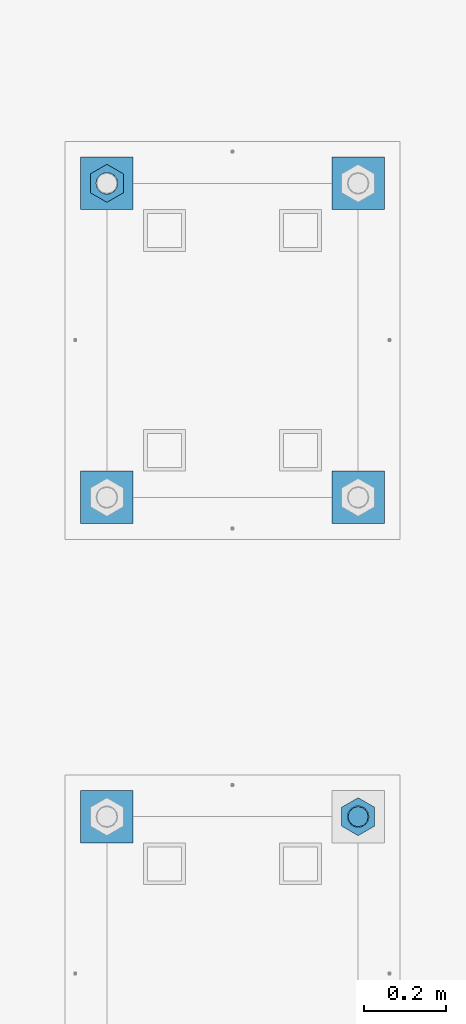
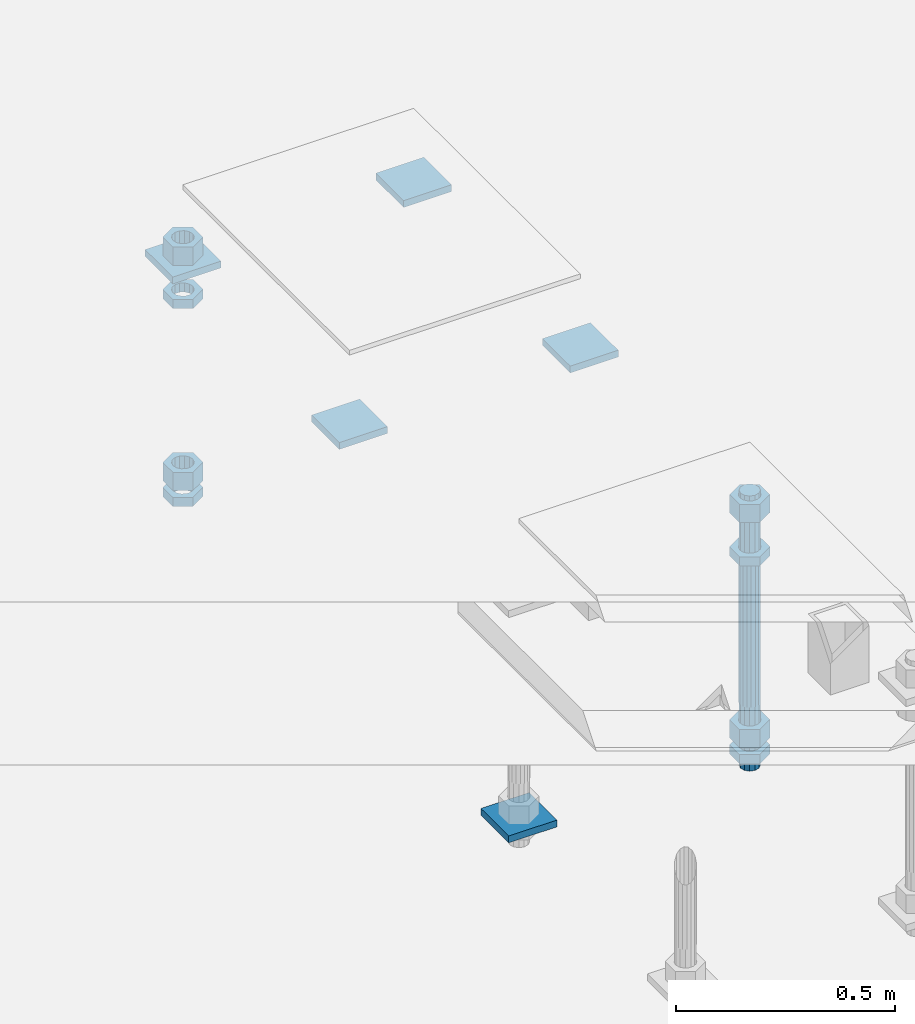
# One storey, part 2617 of 3843: 14 beams, 2 elements without a shape of their own.
"""IFC2X3 building model written with IfcOpenShell, lengths in millimetres."""

from ifc_helpers import new_model, si_unit, frame, origin_with_axes, place, context, subcontext, project, spatial, faceted_brep, material, type_object, element, aggregate, save


model = new_model("IFC2X3")

# Units and contexts
model_context = context("Model", 3, precision=1e-05, world=origin_with_axes())
body_context = subcontext(model_context, "Body", "Model", "MODEL_VIEW")
ifc_project = project(units=[si_unit("LENGTHUNIT", "METRE", prefix="MILLI"), si_unit("AREAUNIT", "SQUARE_METRE"), si_unit("VOLUMEUNIT", "CUBIC_METRE"), si_unit("MASSUNIT", "GRAM", prefix="KILO"), si_unit("TIMEUNIT", "SECOND"), si_unit("PLANEANGLEUNIT", "RADIAN"), si_unit("SOLIDANGLEUNIT", "STERADIAN"), si_unit("THERMODYNAMICTEMPERATUREUNIT", "DEGREE_CELSIUS"), si_unit("LUMINOUSINTENSITYUNIT", "LUMEN")], contexts=[model_context])

# Site, building, storey
site_placement = place(None, origin_with_axes())
site = spatial("IfcSite", under=ifc_project, at=site_placement, CompositionType="ELEMENT")
building_placement = place(site_placement, origin_with_axes())
building = spatial("IfcBuilding", under=site, at=building_placement, Name="Undefined", CompositionType="ELEMENT")
storey_placement = place(building_placement, origin_with_axes())
storey = spatial("IfcBuildingStorey", under=building, at=storey_placement, Name="Undefined", CompositionType="ELEMENT", Elevation=0.0)

# Assembly, beams
assembly_1_placement = place(storey_placement, origin_with_axes())
assembly_1 = element("IfcElementAssembly", 1, at=assembly_1_placement, inside=storey, Name="TEMPLATE", AssemblyPlace="NOTDEFINED", PredefinedType="RIGID_FRAME")
ifc_material_1 = material(Name="STEEL/A36")
beam_type_1 = type_object("IfcBeamType", PredefinedType="NOTDEFINED")
beam_1_placement = place(assembly_1_placement, frame((111798.099998474, 2806.7, 29873.575), z_axis=(0.0, 1.0, 0.0), x_axis=(-1.0, 0.0, 0.0)))
beam_1 = element("IfcBeam", 2, at=beam_1_placement, type_object=beam_type_1, material=ifc_material_1, Name="WASHER_PLATE", context=body_context, shape_type="Brep", body=[
    faceted_brep([(0.0, 9.52500000000146, -63.5), (0.0, 9.52500000000146, 63.5), (127.0, 9.52500000000146, 63.5), (127.0, 9.52500000000146, -63.5), (0.0, -9.52500000000146, 63.5), (127.0, -9.52500000000146, 63.5), (0.0, -9.52500000000146, -63.5), (127.0, -9.52500000000146, -63.5)], [[[0, 1, 2, 3]], [[1, 4, 5, 2]], [[4, 6, 7, 5]], [[6, 0, 3, 7]], [[5, 7, 3, 2]], [[6, 4, 1, 0]]]),
])
beam_2_placement = place(assembly_1_placement, frame((112407.7, 2806.7, 29873.575), z_axis=(0.0, 1.0, 0.0), x_axis=(-1.0, 0.0, 0.0)))
beam_2 = element("IfcBeam", 3, at=beam_2_placement, type_object=beam_type_1, material=ifc_material_1, Name="WASHER_PLATE", context=body_context, shape_type="Brep", body=[
    faceted_brep([(0.0, 9.52500000000146, -63.5), (0.0, 9.52500000000146, 63.5), (127.0, 9.52500000000146, 63.5), (127.0, 9.52500000000146, -63.5), (0.0, -9.52500000000146, 63.5), (127.0, -9.52500000000146, 63.5), (0.0, -9.52500000000146, -63.5), (127.0, -9.52500000000146, -63.5)], [[[0, 1, 2, 3]], [[1, 4, 5, 2]], [[4, 6, 7, 5]], [[6, 0, 3, 7]], [[5, 7, 3, 2]], [[6, 4, 1, 0]]]),
])
beam_3_placement = place(assembly_1_placement, frame((112407.7, 3568.7, 29873.575), z_axis=(0.0, 1.0, 0.0), x_axis=(-1.0, 0.0, 0.0)))
beam_3 = element("IfcBeam", 4, at=beam_3_placement, type_object=beam_type_1, material=ifc_material_1, Name="WASHER_PLATE", context=body_context, shape_type="Brep", body=[
    faceted_brep([(0.0, 9.52500000000146, -63.5), (0.0, 9.52500000000146, 63.5), (127.0, 9.52500000000146, 63.5), (127.0, 9.52500000000146, -63.5), (0.0, -9.52500000000146, 63.5), (127.0, -9.52500000000146, 63.5), (0.0, -9.52500000000146, -63.5), (127.0, -9.52500000000146, -63.5)], [[[0, 1, 2, 3]], [[1, 4, 5, 2]], [[4, 6, 7, 5]], [[6, 0, 3, 7]], [[5, 7, 3, 2]], [[6, 4, 1, 0]]]),
])
beam_4_placement = place(assembly_1_placement, frame((111798.099998474, 3568.7, 29873.575), z_axis=(0.0, 1.0, 0.0), x_axis=(-1.0, 0.0, 0.0)))
beam_4 = element("IfcBeam", 5, at=beam_4_placement, type_object=beam_type_1, material=ifc_material_1, Name="WASHER_PLATE", context=body_context, shape_type="Brep", body=[
    faceted_brep([(0.0, 9.52500000000146, -63.5), (0.0, 9.52500000000146, 63.5), (127.0, 9.52500000000146, 63.5), (127.0, 9.52500000000146, -63.5), (0.0, -9.52500000000146, 63.5), (127.0, -9.52500000000146, 63.5), (0.0, -9.52500000000146, -63.5), (127.0, -9.52500000000146, -63.5)], [[[0, 1, 2, 3]], [[1, 4, 5, 2]], [[4, 6, 7, 5]], [[6, 0, 3, 7]], [[5, 7, 3, 2]], [[6, 4, 1, 0]]]),
])

# Assembly, beam
assembly_2_placement = place(storey_placement, origin_with_axes())
assembly_2 = element("IfcElementAssembly", 6, at=assembly_2_placement, inside=storey, Name="TEMPLATE", AssemblyPlace="NOTDEFINED", PredefinedType="RIGID_FRAME")
beam_5_placement = place(assembly_2_placement, frame((111798.099998474, 2032.00000000001, 29244.925), z_axis=(0.0, 1.0, 0.0), x_axis=(-1.0, 0.0, 0.0)))
beam_5 = element("IfcBeam", 7, at=beam_5_placement, type_object=beam_type_1, material=ifc_material_1, Name="WASHER_PLATE", context=body_context, shape_type="Brep", body=[
    faceted_brep([(0.0, 9.52500000000146, -63.5), (0.0, 9.52500000000146, 63.5), (127.0, 9.52500000000146, 63.5), (127.0, 9.52500000000146, -63.5), (0.0, -9.52500000000146, 63.5), (127.0, -9.52500000000146, 63.5), (0.0, -9.52500000000146, -63.5), (127.0, -9.52500000000146, -63.5)], [[[0, 1, 2, 3]], [[1, 4, 5, 2]], [[4, 6, 7, 5]], [[6, 0, 3, 7]], [[5, 7, 3, 2]], [[6, 4, 1, 0]]]),
])

# Beam
beam_type_2 = type_object("IfcBeamType", Name="2_HALF_NUT", PredefinedType="NOTDEFINED")
beam_6_placement = place(assembly_1_placement, frame((111734.599998474, 3568.70000000001, 29787.85), z_axis=(-1.0, 0.0, 0.0), x_axis=(0.0, 0.0, -1.0)))
beam_6 = element("IfcBeam", 8, at=beam_6_placement, type_object=beam_type_2, material=ifc_material_1, Name="NUT", ObjectType="2_HALF_NUT", context=body_context, shape_type="Brep", body=[
    faceted_brep([(0.0, -46.0369987487793, 0.0), (0.0, -23.0184993743896, -39.869213104248), (25.4000000000015, -23.0184993743896, -39.869213104248), (25.4000000000015, -46.0369987487793, 0.0), (0.0, 23.0184993743896, -39.869213104248), (25.4000000000015, 23.0184993743896, -39.869213104248), (0.0, 46.0369987487793, 0.0), (25.4000000000015, 46.0369987487793, 0.0), (0.0, 23.0184993743896, 39.869213104248), (25.4000000000015, 23.0184993743896, 39.869213104248), (0.0, -23.0184993743896, 39.869213104248), (25.4000000000015, -23.0184993743896, 39.869213104248), (0.0, 0.0, 26.1940002441406), (0.0, 11.3650617044477, 23.5999013092805), (25.4000000000015, 11.3650617044477, 23.5999013092805), (25.4000000000015, 0.0, 26.1940002441406), (0.0, 20.4791109456419, 16.3316083006721), (25.4000000000015, 20.4791109456419, 16.3316083006721), (0.0, 25.5370200498292, 5.82867859874386), (25.4000000000015, 25.5370200498292, 5.82867859874386), (0.0, 25.5370200498292, -5.82867859874386), (25.4000000000015, 25.5370200498292, -5.82867859874386), (0.0, 20.4791109456419, -16.3316083006721), (25.4000000000015, 20.4791109456419, -16.3316083006721), (0.0, 11.3650617044477, -23.5999013092805), (25.4000000000015, 11.3650617044477, -23.5999013092805), (0.0, 0.0, -26.1940002441406), (25.4000000000015, 0.0, -26.1940002441406), (0.0, -11.3650617044477, -23.5999013092805), (25.4000000000015, -11.3650617044477, -23.5999013092805), (0.0, -20.4791109456419, -16.3316083006721), (25.4000000000015, -20.4791109456419, -16.3316083006721), (0.0, -25.5370200498292, -5.82867859874386), (25.4000000000015, -25.5370200498292, -5.82867859874386), (0.0, -25.5370200498292, 5.82867859874386), (25.4000000000015, -25.5370200498292, 5.82867859874386), (0.0, -20.4791109456419, 16.3316083006721), (25.4000000000015, -20.4791109456419, 16.3316083006721), (0.0, -11.3650617044477, 23.5999013092805), (25.4000000000015, -11.3650617044477, 23.5999013092805)], [[[0, 1, 2, 3]], [[1, 4, 5, 2]], [[4, 6, 7, 5]], [[6, 8, 9, 7]], [[8, 10, 11, 9]], [[10, 0, 3, 11]], [[12, 13, 14, 15]], [[13, 16, 17, 14]], [[16, 18, 19, 17]], [[18, 20, 21, 19]], [[20, 22, 23, 21]], [[22, 24, 25, 23]], [[24, 26, 27, 25]], [[26, 28, 29, 27]], [[28, 30, 31, 29]], [[30, 32, 33, 31]], [[32, 34, 35, 33]], [[34, 36, 37, 35]], [[36, 38, 39, 37]], [[38, 12, 15, 39]], [[5, 7, 9, 11, 3, 2], [17, 19, 21, 23, 25, 27, 29, 31, 33, 35, 37, 39, 15, 14]], [[10, 8, 6, 4, 1, 0], [38, 36, 34, 32, 30, 28, 26, 24, 22, 20, 18, 16, 13, 12]]]),
])

beam_7_placement = place(assembly_1_placement, frame((111734.599998474, 3568.7, 29235.4), z_axis=(-1.0, 0.0, 0.0), x_axis=(0.0, 0.0, -1.0)))
beam_7 = element("IfcBeam", 9, at=beam_7_placement, type_object=beam_type_2, material=ifc_material_1, Name="NUT", ObjectType="2_HALF_NUT", context=body_context, shape_type="Brep", body=[
    faceted_brep([(0.0, -46.0369987487793, 0.0), (0.0, -23.0184993743896, -39.869213104248), (25.4000000000015, -23.0184993743896, -39.869213104248), (25.4000000000015, -46.0369987487793, 0.0), (0.0, 23.0184993743896, -39.869213104248), (25.4000000000015, 23.0184993743896, -39.869213104248), (0.0, 46.0369987487793, 0.0), (25.4000000000015, 46.0369987487793, 0.0), (0.0, 23.0184993743896, 39.869213104248), (25.4000000000015, 23.0184993743896, 39.869213104248), (0.0, -23.0184993743896, 39.869213104248), (25.4000000000015, -23.0184993743896, 39.869213104248), (0.0, 0.0, 26.1940002441406), (0.0, 11.3650617044477, 23.5999013092805), (25.4000000000015, 11.3650617044477, 23.5999013092805), (25.4000000000015, 0.0, 26.1940002441406), (0.0, 20.4791109456419, 16.3316083006721), (25.4000000000015, 20.4791109456419, 16.3316083006721), (0.0, 25.5370200498292, 5.82867859874386), (25.4000000000015, 25.5370200498292, 5.82867859874386), (0.0, 25.5370200498292, -5.82867859874386), (25.4000000000015, 25.5370200498292, -5.82867859874386), (0.0, 20.4791109456419, -16.3316083006721), (25.4000000000015, 20.4791109456419, -16.3316083006721), (0.0, 11.3650617044477, -23.5999013092805), (25.4000000000015, 11.3650617044477, -23.5999013092805), (0.0, 0.0, -26.1940002441406), (25.4000000000015, 0.0, -26.1940002441406), (0.0, -11.3650617044477, -23.5999013092805), (25.4000000000015, -11.3650617044477, -23.5999013092805), (0.0, -20.4791109456419, -16.3316083006721), (25.4000000000015, -20.4791109456419, -16.3316083006721), (0.0, -25.5370200498292, -5.82867859874386), (25.4000000000015, -25.5370200498292, -5.82867859874386), (0.0, -25.5370200498292, 5.82867859874386), (25.4000000000015, -25.5370200498292, 5.82867859874386), (0.0, -20.4791109456419, 16.3316083006721), (25.4000000000015, -20.4791109456419, 16.3316083006721), (0.0, -11.3650617044477, 23.5999013092805), (25.4000000000015, -11.3650617044477, 23.5999013092805)], [[[0, 1, 2, 3]], [[1, 4, 5, 2]], [[4, 6, 7, 5]], [[6, 8, 9, 7]], [[8, 10, 11, 9]], [[10, 0, 3, 11]], [[12, 13, 14, 15]], [[13, 16, 17, 14]], [[16, 18, 19, 17]], [[18, 20, 21, 19]], [[20, 22, 23, 21]], [[22, 24, 25, 23]], [[24, 26, 27, 25]], [[26, 28, 29, 27]], [[28, 30, 31, 29]], [[30, 32, 33, 31]], [[32, 34, 35, 33]], [[34, 36, 37, 35]], [[36, 38, 39, 37]], [[38, 12, 15, 39]], [[5, 7, 9, 11, 3, 2], [17, 19, 21, 23, 25, 27, 29, 31, 33, 35, 37, 39, 15, 14]], [[10, 8, 6, 4, 1, 0], [38, 36, 34, 32, 30, 28, 26, 24, 22, 20, 18, 16, 13, 12]]]),
])

beam_8_placement = place(assembly_2_placement, frame((112344.2, 2032.00000000001, 29787.85), z_axis=(-1.0, 0.0, 0.0), x_axis=(0.0, 0.0, -1.0)))
beam_8 = element("IfcBeam", 10, at=beam_8_placement, type_object=beam_type_2, material=ifc_material_1, Name="NUT", ObjectType="2_HALF_NUT", context=body_context, shape_type="Brep", body=[
    faceted_brep([(0.0, -46.0369987487793, 0.0), (0.0, -23.0184993743896, -39.869213104248), (25.4000000000015, -23.0184993743896, -39.869213104248), (25.4000000000015, -46.0369987487793, 0.0), (0.0, 23.0184993743896, -39.869213104248), (25.4000000000015, 23.0184993743896, -39.869213104248), (0.0, 46.0369987487793, 0.0), (25.4000000000015, 46.0369987487793, 0.0), (0.0, 23.0184993743896, 39.869213104248), (25.4000000000015, 23.0184993743896, 39.869213104248), (0.0, -23.0184993743896, 39.869213104248), (25.4000000000015, -23.0184993743896, 39.869213104248), (0.0, 0.0, 26.1940002441406), (0.0, 11.3650617044477, 23.5999013092805), (25.4000000000015, 11.3650617044477, 23.5999013092805), (25.4000000000015, 0.0, 26.1940002441406), (0.0, 20.4791109456419, 16.3316083006721), (25.4000000000015, 20.4791109456419, 16.3316083006721), (0.0, 25.5370200498292, 5.82867859874386), (25.4000000000015, 25.5370200498292, 5.82867859874386), (0.0, 25.5370200498292, -5.82867859874386), (25.4000000000015, 25.5370200498292, -5.82867859874386), (0.0, 20.4791109456419, -16.3316083006721), (25.4000000000015, 20.4791109456419, -16.3316083006721), (0.0, 11.3650617044477, -23.5999013092805), (25.4000000000015, 11.3650617044477, -23.5999013092805), (0.0, 0.0, -26.1940002441406), (25.4000000000015, 0.0, -26.1940002441406), (0.0, -11.3650617044477, -23.5999013092805), (25.4000000000015, -11.3650617044477, -23.5999013092805), (0.0, -20.4791109456419, -16.3316083006721), (25.4000000000015, -20.4791109456419, -16.3316083006721), (0.0, -25.5370200498292, -5.82867859874386), (25.4000000000015, -25.5370200498292, -5.82867859874386), (0.0, -25.5370200498292, 5.82867859874386), (25.4000000000015, -25.5370200498292, 5.82867859874386), (0.0, -20.4791109456419, 16.3316083006721), (25.4000000000015, -20.4791109456419, 16.3316083006721), (0.0, -11.3650617044477, 23.5999013092805), (25.4000000000015, -11.3650617044477, 23.5999013092805)], [[[0, 1, 2, 3]], [[1, 4, 5, 2]], [[4, 6, 7, 5]], [[6, 8, 9, 7]], [[8, 10, 11, 9]], [[10, 0, 3, 11]], [[12, 13, 14, 15]], [[13, 16, 17, 14]], [[16, 18, 19, 17]], [[18, 20, 21, 19]], [[20, 22, 23, 21]], [[22, 24, 25, 23]], [[24, 26, 27, 25]], [[26, 28, 29, 27]], [[28, 30, 31, 29]], [[30, 32, 33, 31]], [[32, 34, 35, 33]], [[34, 36, 37, 35]], [[36, 38, 39, 37]], [[38, 12, 15, 39]], [[5, 7, 9, 11, 3, 2], [17, 19, 21, 23, 25, 27, 29, 31, 33, 35, 37, 39, 15, 14]], [[10, 8, 6, 4, 1, 0], [38, 36, 34, 32, 30, 28, 26, 24, 22, 20, 18, 16, 13, 12]]]),
])

beam_9_placement = place(assembly_2_placement, frame((112344.2, 2032.0, 29235.4), z_axis=(-1.0, 0.0, 0.0), x_axis=(0.0, 0.0, -1.0)))
beam_9 = element("IfcBeam", 11, at=beam_9_placement, type_object=beam_type_2, material=ifc_material_1, Name="NUT", ObjectType="2_HALF_NUT", context=body_context, shape_type="Brep", body=[
    faceted_brep([(0.0, -46.0369987487793, 0.0), (0.0, -23.0184993743896, -39.869213104248), (25.4000000000015, -23.0184993743896, -39.869213104248), (25.4000000000015, -46.0369987487793, 0.0), (0.0, 23.0184993743896, -39.869213104248), (25.4000000000015, 23.0184993743896, -39.869213104248), (0.0, 46.0369987487793, 0.0), (25.4000000000015, 46.0369987487793, 0.0), (0.0, 23.0184993743896, 39.869213104248), (25.4000000000015, 23.0184993743896, 39.869213104248), (0.0, -23.0184993743896, 39.869213104248), (25.4000000000015, -23.0184993743896, 39.869213104248), (0.0, 0.0, 26.1940002441406), (0.0, 11.3650617044477, 23.5999013092805), (25.4000000000015, 11.3650617044477, 23.5999013092805), (25.4000000000015, 0.0, 26.1940002441406), (0.0, 20.4791109456419, 16.3316083006721), (25.4000000000015, 20.4791109456419, 16.3316083006721), (0.0, 25.5370200498292, 5.82867859874386), (25.4000000000015, 25.5370200498292, 5.82867859874386), (0.0, 25.5370200498292, -5.82867859874386), (25.4000000000015, 25.5370200498292, -5.82867859874386), (0.0, 20.4791109456419, -16.3316083006721), (25.4000000000015, 20.4791109456419, -16.3316083006721), (0.0, 11.3650617044477, -23.5999013092805), (25.4000000000015, 11.3650617044477, -23.5999013092805), (0.0, 0.0, -26.1940002441406), (25.4000000000015, 0.0, -26.1940002441406), (0.0, -11.3650617044477, -23.5999013092805), (25.4000000000015, -11.3650617044477, -23.5999013092805), (0.0, -20.4791109456419, -16.3316083006721), (25.4000000000015, -20.4791109456419, -16.3316083006721), (0.0, -25.5370200498292, -5.82867859874386), (25.4000000000015, -25.5370200498292, -5.82867859874386), (0.0, -25.5370200498292, 5.82867859874386), (25.4000000000015, -25.5370200498292, 5.82867859874386), (0.0, -20.4791109456419, 16.3316083006721), (25.4000000000015, -20.4791109456419, 16.3316083006721), (0.0, -11.3650617044477, 23.5999013092805), (25.4000000000015, -11.3650617044477, 23.5999013092805)], [[[0, 1, 2, 3]], [[1, 4, 5, 2]], [[4, 6, 7, 5]], [[6, 8, 9, 7]], [[8, 10, 11, 9]], [[10, 0, 3, 11]], [[12, 13, 14, 15]], [[13, 16, 17, 14]], [[16, 18, 19, 17]], [[18, 20, 21, 19]], [[20, 22, 23, 21]], [[22, 24, 25, 23]], [[24, 26, 27, 25]], [[26, 28, 29, 27]], [[28, 30, 31, 29]], [[30, 32, 33, 31]], [[32, 34, 35, 33]], [[34, 36, 37, 35]], [[36, 38, 39, 37]], [[38, 12, 15, 39]], [[5, 7, 9, 11, 3, 2], [17, 19, 21, 23, 25, 27, 29, 31, 33, 35, 37, 39, 15, 14]], [[10, 8, 6, 4, 1, 0], [38, 36, 34, 32, 30, 28, 26, 24, 22, 20, 18, 16, 13, 12]]]),
])

beam_type_3 = type_object("IfcBeamType", Name="2_HEAVY_HEX_NUT", PredefinedType="NOTDEFINED")
beam_10_placement = place(assembly_1_placement, frame((111734.599998474, 3568.70000000001, 29933.9), z_axis=(-1.0, 0.0, 0.0), x_axis=(0.0, 0.0, -1.0)))
beam_10 = element("IfcBeam", 12, at=beam_10_placement, type_object=beam_type_3, material=ifc_material_1, Name="NUT", ObjectType="2_HEAVY_HEX_NUT", context=body_context, shape_type="Brep", body=[
    faceted_brep([(0.0, -46.0369987487793, 0.0), (0.0, -23.0184993743896, -39.869213104248), (50.7999999999993, -23.0184993743896, -39.869213104248), (50.7999999999993, -46.0369987487793, 0.0), (0.0, 23.0184993743896, -39.869213104248), (50.7999999999993, 23.0184993743896, -39.869213104248), (0.0, 46.0369987487793, 0.0), (50.7999999999993, 46.0369987487793, 0.0), (0.0, 23.0184993743896, 39.869213104248), (50.7999999999993, 23.0184993743896, 39.869213104248), (0.0, -23.0184993743896, 39.869213104248), (50.7999999999993, -23.0184993743896, 39.869213104248), (0.0, 0.0, 26.1940002441406), (0.0, 11.3650617044477, 23.5999013092805), (50.7999999999993, 11.3650617044477, 23.5999013092805), (50.7999999999993, 0.0, 26.1940002441406), (0.0, 20.4791109456419, 16.3316083006721), (50.7999999999993, 20.4791109456419, 16.3316083006721), (0.0, 25.5370200498292, 5.82867859874386), (50.7999999999993, 25.5370200498292, 5.82867859874386), (0.0, 25.5370200498292, -5.82867859874386), (50.7999999999993, 25.5370200498292, -5.82867859874386), (0.0, 20.4791109456419, -16.3316083006721), (50.7999999999993, 20.4791109456419, -16.3316083006721), (0.0, 11.3650617044477, -23.5999013092805), (50.7999999999993, 11.3650617044477, -23.5999013092805), (0.0, 0.0, -26.1940002441406), (50.7999999999993, 0.0, -26.1940002441406), (0.0, -11.3650617044477, -23.5999013092805), (50.7999999999993, -11.3650617044477, -23.5999013092805), (0.0, -20.4791109456419, -16.3316083006721), (50.7999999999993, -20.4791109456419, -16.3316083006721), (0.0, -25.5370200498292, -5.82867859874386), (50.7999999999993, -25.5370200498292, -5.82867859874386), (0.0, -25.5370200498292, 5.82867859874386), (50.7999999999993, -25.5370200498292, 5.82867859874386), (0.0, -20.4791109456419, 16.3316083006721), (50.7999999999993, -20.4791109456419, 16.3316083006721), (0.0, -11.3650617044477, 23.5999013092805), (50.7999999999993, -11.3650617044477, 23.5999013092805)], [[[0, 1, 2, 3]], [[1, 4, 5, 2]], [[4, 6, 7, 5]], [[6, 8, 9, 7]], [[8, 10, 11, 9]], [[10, 0, 3, 11]], [[12, 13, 14, 15]], [[13, 16, 17, 14]], [[16, 18, 19, 17]], [[18, 20, 21, 19]], [[20, 22, 23, 21]], [[22, 24, 25, 23]], [[24, 26, 27, 25]], [[26, 28, 29, 27]], [[28, 30, 31, 29]], [[30, 32, 33, 31]], [[32, 34, 35, 33]], [[34, 36, 37, 35]], [[36, 38, 39, 37]], [[38, 12, 15, 39]], [[5, 7, 9, 11, 3, 2], [17, 19, 21, 23, 25, 27, 29, 31, 33, 35, 37, 39, 15, 14]], [[10, 8, 6, 4, 1, 0], [38, 36, 34, 32, 30, 28, 26, 24, 22, 20, 18, 16, 13, 12]]]),
])

beam_11_placement = place(assembly_1_placement, frame((111734.599998474, 3568.70000000001, 29305.25), z_axis=(-1.0, 0.0, 0.0), x_axis=(0.0, 0.0, -1.0)))
beam_11 = element("IfcBeam", 13, at=beam_11_placement, type_object=beam_type_3, material=ifc_material_1, Name="NUT", ObjectType="2_HEAVY_HEX_NUT", context=body_context, shape_type="Brep", body=[
    faceted_brep([(0.0, -46.0369987487793, 0.0), (0.0, -23.0184993743896, -39.869213104248), (50.7999999999993, -23.0184993743896, -39.869213104248), (50.7999999999993, -46.0369987487793, 0.0), (0.0, 23.0184993743896, -39.869213104248), (50.7999999999993, 23.0184993743896, -39.869213104248), (0.0, 46.0369987487793, 0.0), (50.7999999999993, 46.0369987487793, 0.0), (0.0, 23.0184993743896, 39.869213104248), (50.7999999999993, 23.0184993743896, 39.869213104248), (0.0, -23.0184993743896, 39.869213104248), (50.7999999999993, -23.0184993743896, 39.869213104248), (0.0, 0.0, 26.1940002441406), (0.0, 11.3650617044477, 23.5999013092805), (50.7999999999993, 11.3650617044477, 23.5999013092805), (50.7999999999993, 0.0, 26.1940002441406), (0.0, 20.4791109456419, 16.3316083006721), (50.7999999999993, 20.4791109456419, 16.3316083006721), (0.0, 25.5370200498292, 5.82867859874386), (50.7999999999993, 25.5370200498292, 5.82867859874386), (0.0, 25.5370200498292, -5.82867859874386), (50.7999999999993, 25.5370200498292, -5.82867859874386), (0.0, 20.4791109456419, -16.3316083006721), (50.7999999999993, 20.4791109456419, -16.3316083006721), (0.0, 11.3650617044477, -23.5999013092805), (50.7999999999993, 11.3650617044477, -23.5999013092805), (0.0, 0.0, -26.1940002441406), (50.7999999999993, 0.0, -26.1940002441406), (0.0, -11.3650617044477, -23.5999013092805), (50.7999999999993, -11.3650617044477, -23.5999013092805), (0.0, -20.4791109456419, -16.3316083006721), (50.7999999999993, -20.4791109456419, -16.3316083006721), (0.0, -25.5370200498292, -5.82867859874386), (50.7999999999993, -25.5370200498292, -5.82867859874386), (0.0, -25.5370200498292, 5.82867859874386), (50.7999999999993, -25.5370200498292, 5.82867859874386), (0.0, -20.4791109456419, 16.3316083006721), (50.7999999999993, -20.4791109456419, 16.3316083006721), (0.0, -11.3650617044477, 23.5999013092805), (50.7999999999993, -11.3650617044477, 23.5999013092805)], [[[0, 1, 2, 3]], [[1, 4, 5, 2]], [[4, 6, 7, 5]], [[6, 8, 9, 7]], [[8, 10, 11, 9]], [[10, 0, 3, 11]], [[12, 13, 14, 15]], [[13, 16, 17, 14]], [[16, 18, 19, 17]], [[18, 20, 21, 19]], [[20, 22, 23, 21]], [[22, 24, 25, 23]], [[24, 26, 27, 25]], [[26, 28, 29, 27]], [[28, 30, 31, 29]], [[30, 32, 33, 31]], [[32, 34, 35, 33]], [[34, 36, 37, 35]], [[36, 38, 39, 37]], [[38, 12, 15, 39]], [[5, 7, 9, 11, 3, 2], [17, 19, 21, 23, 25, 27, 29, 31, 33, 35, 37, 39, 15, 14]], [[10, 8, 6, 4, 1, 0], [38, 36, 34, 32, 30, 28, 26, 24, 22, 20, 18, 16, 13, 12]]]),
])

aggregate(assembly_1, [beam_1, beam_2, beam_3, beam_4, beam_6, beam_10, beam_11, beam_7])

beam_12_placement = place(assembly_2_placement, frame((112344.2, 2032.00000000001, 29933.9), z_axis=(-1.0, 0.0, 0.0), x_axis=(0.0, 0.0, -1.0)))
beam_12 = element("IfcBeam", 14, at=beam_12_placement, type_object=beam_type_3, material=ifc_material_1, Name="NUT", ObjectType="2_HEAVY_HEX_NUT", context=body_context, shape_type="Brep", body=[
    faceted_brep([(0.0, -46.0369987487793, 0.0), (0.0, -23.0184993743896, -39.869213104248), (50.7999999999993, -23.0184993743896, -39.869213104248), (50.7999999999993, -46.0369987487793, 0.0), (0.0, 23.0184993743896, -39.869213104248), (50.7999999999993, 23.0184993743896, -39.869213104248), (0.0, 46.0369987487793, 0.0), (50.7999999999993, 46.0369987487793, 0.0), (0.0, 23.0184993743896, 39.869213104248), (50.7999999999993, 23.0184993743896, 39.869213104248), (0.0, -23.0184993743896, 39.869213104248), (50.7999999999993, -23.0184993743896, 39.869213104248), (0.0, 0.0, 26.1940002441406), (0.0, 11.3650617044477, 23.5999013092805), (50.7999999999993, 11.3650617044477, 23.5999013092805), (50.7999999999993, 0.0, 26.1940002441406), (0.0, 20.4791109456419, 16.3316083006721), (50.7999999999993, 20.4791109456419, 16.3316083006721), (0.0, 25.5370200498292, 5.82867859874386), (50.7999999999993, 25.5370200498292, 5.82867859874386), (0.0, 25.5370200498292, -5.82867859874386), (50.7999999999993, 25.5370200498292, -5.82867859874386), (0.0, 20.4791109456419, -16.3316083006721), (50.7999999999993, 20.4791109456419, -16.3316083006721), (0.0, 11.3650617044477, -23.5999013092805), (50.7999999999993, 11.3650617044477, -23.5999013092805), (0.0, 0.0, -26.1940002441406), (50.7999999999993, 0.0, -26.1940002441406), (0.0, -11.3650617044477, -23.5999013092805), (50.7999999999993, -11.3650617044477, -23.5999013092805), (0.0, -20.4791109456419, -16.3316083006721), (50.7999999999993, -20.4791109456419, -16.3316083006721), (0.0, -25.5370200498292, -5.82867859874386), (50.7999999999993, -25.5370200498292, -5.82867859874386), (0.0, -25.5370200498292, 5.82867859874386), (50.7999999999993, -25.5370200498292, 5.82867859874386), (0.0, -20.4791109456419, 16.3316083006721), (50.7999999999993, -20.4791109456419, 16.3316083006721), (0.0, -11.3650617044477, 23.5999013092805), (50.7999999999993, -11.3650617044477, 23.5999013092805)], [[[0, 1, 2, 3]], [[1, 4, 5, 2]], [[4, 6, 7, 5]], [[6, 8, 9, 7]], [[8, 10, 11, 9]], [[10, 0, 3, 11]], [[12, 13, 14, 15]], [[13, 16, 17, 14]], [[16, 18, 19, 17]], [[18, 20, 21, 19]], [[20, 22, 23, 21]], [[22, 24, 25, 23]], [[24, 26, 27, 25]], [[26, 28, 29, 27]], [[28, 30, 31, 29]], [[30, 32, 33, 31]], [[32, 34, 35, 33]], [[34, 36, 37, 35]], [[36, 38, 39, 37]], [[38, 12, 15, 39]], [[5, 7, 9, 11, 3, 2], [17, 19, 21, 23, 25, 27, 29, 31, 33, 35, 37, 39, 15, 14]], [[10, 8, 6, 4, 1, 0], [38, 36, 34, 32, 30, 28, 26, 24, 22, 20, 18, 16, 13, 12]]]),
])

beam_13_placement = place(assembly_2_placement, frame((112344.2, 2032.00000000001, 29305.25), z_axis=(-1.0, 0.0, 0.0), x_axis=(0.0, 0.0, -1.0)))
beam_13 = element("IfcBeam", 15, at=beam_13_placement, type_object=beam_type_3, material=ifc_material_1, Name="NUT", ObjectType="2_HEAVY_HEX_NUT", context=body_context, shape_type="Brep", body=[
    faceted_brep([(0.0, -46.0369987487793, 0.0), (0.0, -23.0184993743896, -39.869213104248), (50.7999999999993, -23.0184993743896, -39.869213104248), (50.7999999999993, -46.0369987487793, 0.0), (0.0, 23.0184993743896, -39.869213104248), (50.7999999999993, 23.0184993743896, -39.869213104248), (0.0, 46.0369987487793, 0.0), (50.7999999999993, 46.0369987487793, 0.0), (0.0, 23.0184993743896, 39.869213104248), (50.7999999999993, 23.0184993743896, 39.869213104248), (0.0, -23.0184993743896, 39.869213104248), (50.7999999999993, -23.0184993743896, 39.869213104248), (0.0, 0.0, 26.1940002441406), (0.0, 11.3650617044477, 23.5999013092805), (50.7999999999993, 11.3650617044477, 23.5999013092805), (50.7999999999993, 0.0, 26.1940002441406), (0.0, 20.4791109456419, 16.3316083006721), (50.7999999999993, 20.4791109456419, 16.3316083006721), (0.0, 25.5370200498292, 5.82867859874386), (50.7999999999993, 25.5370200498292, 5.82867859874386), (0.0, 25.5370200498292, -5.82867859874386), (50.7999999999993, 25.5370200498292, -5.82867859874386), (0.0, 20.4791109456419, -16.3316083006721), (50.7999999999993, 20.4791109456419, -16.3316083006721), (0.0, 11.3650617044477, -23.5999013092805), (50.7999999999993, 11.3650617044477, -23.5999013092805), (0.0, 0.0, -26.1940002441406), (50.7999999999993, 0.0, -26.1940002441406), (0.0, -11.3650617044477, -23.5999013092805), (50.7999999999993, -11.3650617044477, -23.5999013092805), (0.0, -20.4791109456419, -16.3316083006721), (50.7999999999993, -20.4791109456419, -16.3316083006721), (0.0, -25.5370200498292, -5.82867859874386), (50.7999999999993, -25.5370200498292, -5.82867859874386), (0.0, -25.5370200498292, 5.82867859874386), (50.7999999999993, -25.5370200498292, 5.82867859874386), (0.0, -20.4791109456419, 16.3316083006721), (50.7999999999993, -20.4791109456419, 16.3316083006721), (0.0, -11.3650617044477, 23.5999013092805), (50.7999999999993, -11.3650617044477, 23.5999013092805)], [[[0, 1, 2, 3]], [[1, 4, 5, 2]], [[4, 6, 7, 5]], [[6, 8, 9, 7]], [[8, 10, 11, 9]], [[10, 0, 3, 11]], [[12, 13, 14, 15]], [[13, 16, 17, 14]], [[16, 18, 19, 17]], [[18, 20, 21, 19]], [[20, 22, 23, 21]], [[22, 24, 25, 23]], [[24, 26, 27, 25]], [[26, 28, 29, 27]], [[28, 30, 31, 29]], [[30, 32, 33, 31]], [[32, 34, 35, 33]], [[34, 36, 37, 35]], [[36, 38, 39, 37]], [[38, 12, 15, 39]], [[5, 7, 9, 11, 3, 2], [17, 19, 21, 23, 25, 27, 29, 31, 33, 35, 37, 39, 15, 14]], [[10, 8, 6, 4, 1, 0], [38, 36, 34, 32, 30, 28, 26, 24, 22, 20, 18, 16, 13, 12]]]),
])

ifc_material_2 = material()
beam_type_4 = type_object("IfcBeamType", PredefinedType="NOTDEFINED")
beam_14_placement = place(assembly_2_placement, frame((112344.2, 2032.00000000001, 29762.45), z_axis=(-1.0, 0.0, 0.0), x_axis=(0.0, 0.0, -1.0)))
beam_14 = element("IfcBeam", 16, at=beam_14_placement, type_object=beam_type_4, material=ifc_material_2, Name="ANCHOR_ROD", context=body_context, shape_type="Brep", body=[
    faceted_brep([(-184.150000000001, -21.217622392709, 12.25), (-184.150000000001, -12.2499999999854, 21.2176223927163), (-184.150000000001, 1.45519152283669e-11, 24.5), (-184.150000000001, 12.2500000000146, 21.2176223927163), (-184.150000000001, 21.2176223927381, 12.25), (-184.150000000001, 24.5000000000146, 0.0), (-184.150000000001, 21.2176223927381, -12.25), (-184.150000000001, 12.2500000000146, -21.2176223927163), (-184.150000000001, 1.45519152283669e-11, -24.5), (-184.150000000001, -12.2499999999854, -21.2176223927163), (-184.150000000001, -21.217622392709, -12.25), (-184.150000000001, -24.4999999999854, 0.0), (0.0, 24.5000000000146, 0.0), (0.0, 21.2176223927381, -12.25), (0.0, 12.2500000000146, -21.2176223927163), (0.0, 1.45519152283669e-11, -24.5), (0.0, -12.2499999999854, -21.2176223927163), (0.0, -21.217622392709, -12.25), (0.0, -24.4999999999854, 0.0), (0.0, -21.217622392709, 12.25), (0.0, -12.2499999999854, 21.2176223927163), (0.0, 1.45519152283669e-11, 24.5), (0.0, 12.2500000000146, 21.2176223927163), (0.0, 21.2176223927381, 12.25), (0.0, -23.4665401257807, 9.72015918207035), (0.0, -17.9605122421344, 17.9605122421417), (0.0, -9.72015918207762, 23.466540125788), (0.0, 0.0, 25.4000000000015), (0.0, 9.72015918207762, 23.466540125788), (0.0, 17.9605122421344, 17.9605122421417), (0.0, 23.4665401257807, 9.72015918207035), (0.0, 25.3999996185303, 0.0), (0.0, 23.4665401257807, -9.72015918207035), (0.0, 17.9605122421344, -17.9605122421417), (0.0, 9.72015918207762, -23.466540125788), (0.0, 0.0, -25.4000000000015), (0.0, -9.72015918207762, -23.466540125788), (0.0, -17.9605122421344, -17.9605122421417), (0.0, -23.4665401257807, -9.72015918207035), (0.0, -25.3999996185303, 0.0), (406.399999999998, -25.3999999999942, 0.0), (406.399999999998, -23.4665401257807, 9.72015918207035), (406.399999999998, -17.9605122421344, 17.9605122421417), (406.399999999998, -9.72015918207762, 23.466540125788), (406.399999999998, 0.0, 25.4000000000015), (406.399999999998, 9.72015918207762, 23.466540125788), (406.399999999998, 17.9605122421344, 17.9605122421417), (406.399999999998, 23.4665401257807, 9.72015918207035), (406.399999999998, 25.3999999999942, 0.0), (406.399999999998, 23.4665401257807, -9.72015918207035), (406.399999999998, 17.9605122421344, -17.9605122421417), (406.399999999998, 9.72015918207762, -23.466540125788), (406.399999999998, 0.0, -25.4000000000015), (406.399999999998, -9.72015918207762, -23.466540125788), (406.399999999998, -17.9605122421344, -17.9605122421417), (406.399999999998, -23.4665401257807, -9.72015918207035), (406.399999999998, -12.2499999999854, 21.2176223927163), (406.399999999998, 1.45519152283669e-11, 24.5), (406.399999999998, 12.2500000000146, 21.2176223927163), (406.399999999998, 21.2176223927381, 12.25), (406.399999999998, 24.5000000000146, 0.0), (406.399999999998, 21.2176223927381, -12.25), (406.399999999998, 12.2500000000146, -21.2176223927163), (406.399999999998, 1.45519152283669e-11, -24.5), (406.399999999998, -12.2499999999854, -21.2176223927163), (406.399999999998, -21.217622392709, -12.25), (406.399999999998, -24.4999999999854, 0.0), (406.399999999998, -21.217622392709, 12.25), (584.200000000001, -12.2499999999854, -21.2176223927163), (584.200000000001, 1.45519152283669e-11, -24.5), (584.200000000001, 12.2500000000146, -21.2176223927163), (584.200000000001, 21.2176223927381, -12.25), (584.200000000001, 24.5000000000146, 0.0), (584.200000000001, 21.2176223927381, 12.25), (584.200000000001, 12.2500000000146, 21.2176223927163), (584.200000000001, 1.45519152283669e-11, 24.5), (584.200000000001, -12.2499999999854, 21.2176223927163), (584.200000000001, -21.217622392709, 12.25), (584.200000000001, -24.4999999999854, 0.0), (584.200000000001, -21.217622392709, -12.25)], [[[0, 1, 2, 3, 4, 5, 6, 7, 8, 9, 10, 11]], [[6, 5, 12, 13]], [[7, 6, 13, 14]], [[8, 7, 14, 15]], [[9, 8, 15, 16]], [[10, 9, 16, 17]], [[11, 10, 17, 18]], [[0, 11, 18, 19]], [[1, 0, 19, 20]], [[2, 1, 20, 21]], [[3, 2, 21, 22]], [[4, 3, 22, 23]], [[5, 4, 23, 12]], [[24, 25, 26, 27, 28, 29, 30, 31, 32, 33, 34, 35, 36, 37, 38, 39], [22, 21, 20, 19, 18, 17, 16, 15, 14, 13, 12, 23]], [[24, 39, 40, 41]], [[25, 24, 41, 42]], [[26, 25, 42, 43]], [[27, 26, 43, 44]], [[28, 27, 44, 45]], [[29, 28, 45, 46]], [[30, 29, 46, 47]], [[31, 30, 47, 48]], [[32, 31, 48, 49]], [[33, 32, 49, 50]], [[34, 33, 50, 51]], [[35, 34, 51, 52]], [[36, 35, 52, 53]], [[37, 36, 53, 54]], [[38, 37, 54, 55]], [[39, 38, 55, 40]], [[54, 53, 52, 51, 50, 49, 48, 47, 46, 45, 44, 43, 42, 41, 40, 55], [56, 57, 58, 59, 60, 61, 62, 63, 64, 65, 66, 67]], [[68, 69, 70, 71, 72, 73, 74, 75, 76, 77, 78, 79]], [[76, 75, 57, 56]], [[77, 76, 56, 67]], [[78, 77, 67, 66]], [[79, 78, 66, 65]], [[68, 79, 65, 64]], [[69, 68, 64, 63]], [[70, 69, 63, 62]], [[71, 70, 62, 61]], [[72, 71, 61, 60]], [[73, 72, 60, 59]], [[74, 73, 59, 58]], [[75, 74, 58, 57]]]),
])

aggregate(assembly_2, [beam_8, beam_12, beam_13, beam_9, beam_14, beam_5])

save(model, "model.ifc")
